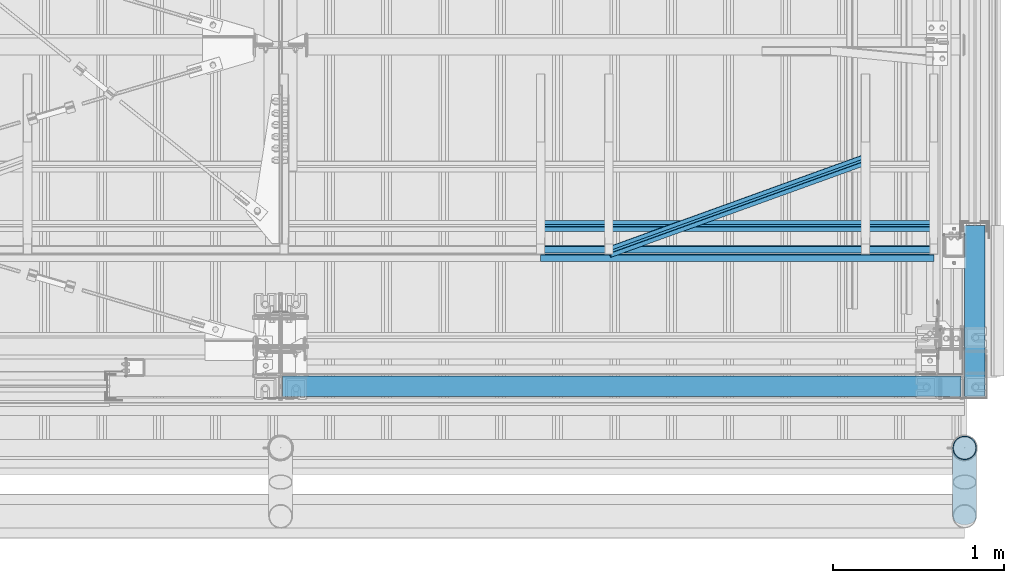
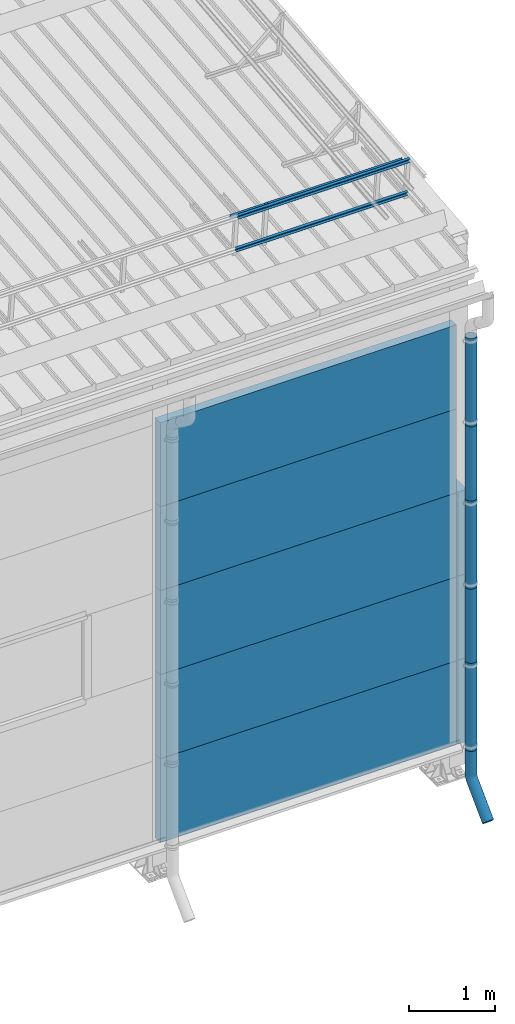
# One storey, part 69 of 709: 18 beams, 18 elements without a shape of their own.
"""IFC4 building model written with IfcOpenShell, lengths in millimetres."""

from ifc_helpers import new_model, entity, si_unit, direction, frame, origin_with_axes, place, context, subcontext, project, spatial, line, indexed_curve, outline, extrude, material, element, aggregate, save


model = new_model("IFC4")

# Units and contexts
model_context = context("Model", 3, precision=0.2, world=origin_with_axes(), true_north=direction((0.0, 1.0)))
body_context = subcontext(model_context, "Body", "Model", "MODEL_VIEW")
ifc_project = project(units=[si_unit("LENGTHUNIT", "METRE", prefix="MILLI"), si_unit("AREAUNIT", "SQUARE_METRE"), si_unit("VOLUMEUNIT", "CUBIC_METRE"), si_unit("MASSUNIT", "GRAM", prefix="KILO"), si_unit("TIMEUNIT", "SECOND"), si_unit("PLANEANGLEUNIT", "RADIAN"), si_unit("SOLIDANGLEUNIT", "STERADIAN"), si_unit("THERMODYNAMICTEMPERATUREUNIT", "DEGREE_CELSIUS"), si_unit("LUMINOUSINTENSITYUNIT", "LUMEN")], contexts=[model_context])

# Site, building, storey
site_placement = place(None, origin_with_axes())
site = spatial("IfcSite", under=ifc_project, at=site_placement, CompositionType="ELEMENT")
building_placement = place(site_placement, origin_with_axes())
building = spatial("IfcBuilding", under=site, at=building_placement, Name="Undefined", CompositionType="ELEMENT")
storey_placement = place(building_placement, origin_with_axes())
storey = spatial("IfcBuildingStorey", under=building, at=storey_placement, Name="Undefined", CompositionType="ELEMENT", Elevation=0.0)

# Assembly, beam
assembly_1_placement = place(storey_placement, frame((47520.0, 691.31008, 8152.29341), z_axis=(0.0, -0.9950371902, -0.099503719), x_axis=(1.0, 0.0, 0.0)))
assembly_1 = element("IfcElementAssembly", 1, at=assembly_1_placement, inside=storey)
ifc_material_1 = material(Name="Steel_Undefined", Category="STEEL")
beam_1_placement = place(assembly_1_placement, origin_with_axes())
beam_1 = element("IfcBeam", 2, at=beam_1_placement, material=ifc_material_1, ObjectType="607", context=body_context, shape_type="SolidModel", body=[
    extrude(outline(indexed_curve([(-20.0, -25.0), (20.0, -25.0), (20.0, -22.5), (-17.5, -22.5), (-17.5, 22.5), (20.0, 22.5), (20.0, 25.0), (-20.0, 25.0)], segments=[line(1, 2, 3, 4, 5, 6, 7, 8, 1)])), frame((0.0, 0.0, 0.0), z_axis=(-1.0, 0.0, 0.0), x_axis=(0.0, 0.0, 1.0)), (0.0, 0.0, -1.0), 2300.0),
])
aggregate(assembly_1, [beam_1])

assembly_2_placement = place(storey_placement, frame((47520.0, 741.06194, 7654.77481), z_axis=(0.0, -0.9950371902, -0.099503719), x_axis=(1.0, 0.0, 0.0)))
assembly_2 = element("IfcElementAssembly", 3, at=assembly_2_placement, inside=storey)
beam_2_placement = place(assembly_2_placement, origin_with_axes())
beam_2 = element("IfcBeam", 4, at=beam_2_placement, material=ifc_material_1, ObjectType="607", context=body_context, shape_type="SolidModel", body=[
    extrude(outline(indexed_curve([(-20.0, -25.0), (20.0, -25.0), (20.0, -22.5), (-17.5, -22.5), (-17.5, 22.5), (20.0, 22.5), (20.0, 25.0), (-20.0, 25.0)], segments=[line(1, 2, 3, 4, 5, 6, 7, 8, 1)])), frame((0.0, 0.0, 0.0), z_axis=(-1.0, 0.0, 0.0), x_axis=(0.0, 0.0, 1.0)), (0.0, 0.0, -1.0), 2300.0),
])
aggregate(assembly_2, [beam_2])

assembly_3_placement = place(storey_placement, frame((47520.0, 878.66704, 8043.11507), z_axis=(0.0, 0.6332377902, 0.7739572992), x_axis=(1.0, 0.0, 0.0)))
assembly_3 = element("IfcElementAssembly", 5, at=assembly_3_placement, inside=storey)
beam_3_placement = place(assembly_3_placement, origin_with_axes())
beam_3 = element("IfcBeam", 6, at=beam_3_placement, material=ifc_material_1, ObjectType="607", context=body_context, shape_type="SolidModel", body=[
    extrude(outline(indexed_curve([(-20.0, -25.0), (20.0, -25.0), (20.0, -22.5), (-17.5, -22.5), (-17.5, 22.5), (20.0, 22.5), (20.0, 25.0), (-20.0, 25.0)], segments=[line(1, 2, 3, 4, 5, 6, 7, 8, 1)])), frame((0.0, 0.0, 0.0), z_axis=(-1.0, 0.0, 0.0), x_axis=(0.0, 0.0, 1.0)), (0.0, 0.0, -1.0), 2300.0),
])
aggregate(assembly_3, [beam_3])

assembly_4_placement = place(storey_placement, frame((47920.0, 723.87558, 8169.76263), z_axis=(0.0, 0.6332377902, 0.7739572992), x_axis=(0.9061831398, 0.3272952929, -0.2677870579)))
assembly_4 = element("IfcElementAssembly", 7, at=assembly_4_placement, inside=storey)
beam_4_placement = place(assembly_4_placement, origin_with_axes())
beam_4 = element("IfcBeam", 8, at=beam_4_placement, material=ifc_material_1, ObjectType="605", context=body_context, shape_type="SolidModel", body=[
    extrude(outline(indexed_curve([(-20.0, -25.0), (20.0, -25.0), (20.0, -22.5), (-17.5, -22.5), (-17.5, 22.5), (20.0, 22.5), (20.0, 25.0), (-20.0, 25.0)], segments=[line(1, 2, 3, 4, 5, 6, 7, 8, 1)])), frame((0.0, 0.0, 0.0), z_axis=(-1.0, 0.0, 0.0), x_axis=(0.0, 0.0, 1.0)), (0.0, 0.0, -1.0), 1655.29454),
])
aggregate(assembly_4, [beam_4])

assembly_5_placement = place(storey_placement, frame((46010.0, -60.0, 895.0), z_axis=(0.0, 0.0, -1.0), x_axis=(1.0, 0.0, 0.0)))
assembly_5 = element("IfcElementAssembly", 9, at=assembly_5_placement, inside=storey)
ifc_material_2 = material(Name="Insulation", Category="Insulation")
beam_5_placement = place(assembly_5_placement, origin_with_axes())
beam_5 = element("IfcBeam", 10, at=beam_5_placement, material=ifc_material_2, ObjectType="P-102", context=body_context, shape_type="SolidModel", body=[
    extrude(outline(indexed_curve([(-595.0, -60.0), (595.0, -60.0), (595.0, 60.0), (-595.0, 60.0)], segments=[line(1, 2, 3, 4, 1)])), frame((0.0, 0.0, 0.0), z_axis=(-1.0, 0.0, 0.0), x_axis=(0.0, 0.0, 1.0)), (0.0, 0.0, -1.0), 3970.0),
])
aggregate(assembly_5, [beam_5])

assembly_6_placement = place(storey_placement, frame((46010.0, -60.0, 2085.0), z_axis=(0.0, 0.0, -1.0), x_axis=(1.0, 0.0, 0.0)))
assembly_6 = element("IfcElementAssembly", 11, at=assembly_6_placement, inside=storey)
beam_6_placement = place(assembly_6_placement, origin_with_axes())
beam_6 = element("IfcBeam", 12, at=beam_6_placement, material=ifc_material_2, ObjectType="P-102", context=body_context, shape_type="SolidModel", body=[
    extrude(outline(indexed_curve([(-595.0, -60.0), (595.0, -60.0), (595.0, 60.0), (-595.0, 60.0)], segments=[line(1, 2, 3, 4, 1)])), frame((0.0, 0.0, 0.0), z_axis=(-1.0, 0.0, 0.0), x_axis=(0.0, 0.0, 1.0)), (0.0, 0.0, -1.0), 3970.0),
])
aggregate(assembly_6, [beam_6])

assembly_7_placement = place(storey_placement, frame((46010.0, -60.0, 3275.0), z_axis=(0.0, 0.0, -1.0), x_axis=(1.0, 0.0, 0.0)))
assembly_7 = element("IfcElementAssembly", 13, at=assembly_7_placement, inside=storey)
beam_7_placement = place(assembly_7_placement, origin_with_axes())
beam_7 = element("IfcBeam", 14, at=beam_7_placement, material=ifc_material_2, ObjectType="P-102", context=body_context, shape_type="SolidModel", body=[
    extrude(outline(indexed_curve([(-595.0, -60.0), (595.0, -60.0), (595.0, 60.0), (-595.0, 60.0)], segments=[line(1, 2, 3, 4, 1)])), frame((0.0, 0.0, 0.0), z_axis=(-1.0, 0.0, 0.0), x_axis=(0.0, 0.0, 1.0)), (0.0, 0.0, -1.0), 3970.0),
])
aggregate(assembly_7, [beam_7])

assembly_8_placement = place(storey_placement, frame((46010.0, -60.0, 4465.0), z_axis=(0.0, 0.0, -1.0), x_axis=(1.0, 0.0, 0.0)))
assembly_8 = element("IfcElementAssembly", 15, at=assembly_8_placement, inside=storey)
beam_8_placement = place(assembly_8_placement, origin_with_axes())
beam_8 = element("IfcBeam", 16, at=beam_8_placement, material=ifc_material_2, ObjectType="P-102", context=body_context, shape_type="SolidModel", body=[
    extrude(outline(indexed_curve([(-595.0, -60.0), (595.0, -60.0), (595.0, 60.0), (-595.0, 60.0)], segments=[line(1, 2, 3, 4, 1)])), frame((0.0, 0.0, 0.0), z_axis=(-1.0, 0.0, 0.0), x_axis=(0.0, 0.0, 1.0)), (0.0, 0.0, -1.0), 3970.0),
])
aggregate(assembly_8, [beam_8])

assembly_9_placement = place(storey_placement, frame((46010.0, -60.0, 5655.0), z_axis=(0.0, 0.0, -1.0), x_axis=(1.0, 0.0, 0.0)))
assembly_9 = element("IfcElementAssembly", 17, at=assembly_9_placement, inside=storey)
beam_9_placement = place(assembly_9_placement, origin_with_axes())
beam_9 = element("IfcBeam", 18, at=beam_9_placement, material=ifc_material_2, ObjectType="P-102", context=body_context, shape_type="SolidModel", body=[
    extrude(outline(indexed_curve([(-595.0, -60.0), (595.0, -60.0), (595.0, 60.0), (-595.0, 60.0)], segments=[line(1, 2, 3, 4, 1)])), frame((0.0, 0.0, 0.0), z_axis=(-1.0, 0.0, 0.0), x_axis=(0.0, 0.0, 1.0)), (0.0, 0.0, -1.0), 3970.0),
])
aggregate(assembly_9, [beam_9])

assembly_10_placement = place(storey_placement, frame((50000.0, -420.0, 6276.92297), z_axis=(0.0, 1.0, 0.0), x_axis=(0.0, 0.0, -1.0)))
assembly_10 = element("IfcElementAssembly", 19, at=assembly_10_placement, inside=storey)
beam_10_placement = place(assembly_10_placement, origin_with_axes())
beam_10 = element("IfcBeam", 20, at=beam_10_placement, material=ifc_material_1, ObjectType="614", context=body_context, shape_type="SolidModel", body=[
    extrude(outline(indexed_curve([(70.0, 0.0), (69.61653, 7.31699), (68.47033, 14.55382), (66.57396, 21.63119), (63.94818, 28.47157), (60.62178, 35.0), (56.63119, 41.14497), (52.02014, 46.83914), (46.83914, 52.02014), (41.14497, 56.63119), (35.0, 60.62178), (28.47157, 63.94818), (21.63119, 66.57396), (14.55382, 68.47033), (7.31699, 69.61653), (0.0, 70.0), (-7.31699, 69.61653), (-14.55382, 68.47033), (-21.63119, 66.57396), (-28.47157, 63.94818), (-35.0, 60.62178), (-41.14497, 56.63119), (-46.83914, 52.02014), (-52.02014, 46.83914), (-56.63119, 41.14497), (-60.62178, 35.0), (-63.94818, 28.47157), (-66.57396, 21.63119), (-68.47033, 14.55382), (-69.61653, 7.31699), (-70.0, 0.0), (-69.61653, -7.31699), (-68.47033, -14.55382), (-66.57396, -21.63119), (-63.94818, -28.47157), (-60.62178, -35.0), (-56.63119, -41.14497), (-52.02014, -46.83914), (-46.83914, -52.02014), (-41.14497, -56.63119), (-35.0, -60.62178), (-28.47157, -63.94818), (-21.63119, -66.57396), (-14.55382, -68.47033), (-7.31699, -69.61653), (0.0, -70.0), (7.31699, -69.61653), (14.55382, -68.47033), (21.63119, -66.57396), (28.47157, -63.94818), (35.0, -60.62178), (41.14497, -56.63119), (46.83914, -52.02014), (52.02014, -46.83914), (56.63119, -41.14497), (60.62178, -35.0), (63.94818, -28.47157), (66.57396, -21.63119), (68.47033, -14.55382), (69.61653, -7.31699)], segments=[line(1, 2, 3, 4, 5, 6, 7, 8, 9, 10, 11, 12, 13, 14, 15, 16, 17, 18, 19, 20, 21, 22, 23, 24, 25, 26, 27, 28, 29, 30, 31, 32, 33, 34, 35, 36, 37, 38, 39, 40, 41, 42, 43, 44, 45, 46, 47, 48, 49, 50, 51, 52, 53, 54, 55, 56, 57, 58, 59, 60, 1)]), holes=[indexed_curve([(65.0, 0.0), (64.64392, -6.79435), (63.57959, -13.51426), (61.81867, -20.0861), (59.38045, -26.43788), (56.29165, -32.5), (52.5861, -38.20604), (48.30441, -43.49349), (43.49349, -48.30441), (38.20604, -52.5861), (32.5, -56.29165), (26.43788, -59.38045), (20.0861, -61.81867), (13.51426, -63.57959), (6.79435, -64.64392), (0.0, -65.0), (-6.79435, -64.64392), (-13.51426, -63.57959), (-20.0861, -61.81867), (-26.43788, -59.38045), (-32.5, -56.29165), (-38.20604, -52.5861), (-43.49349, -48.30441), (-48.30441, -43.49349), (-52.5861, -38.20604), (-56.29165, -32.5), (-59.38045, -26.43788), (-61.81867, -20.0861), (-63.57959, -13.51426), (-64.64392, -6.79435), (-65.0, 0.0), (-64.64392, 6.79435), (-63.57959, 13.51426), (-61.81867, 20.0861), (-59.38045, 26.43788), (-56.29165, 32.5), (-52.5861, 38.20604), (-48.30441, 43.49349), (-43.49349, 48.30441), (-38.20604, 52.5861), (-32.5, 56.29165), (-26.43788, 59.38045), (-20.0861, 61.81867), (-13.51426, 63.57959), (-6.79435, 64.64392), (0.0, 65.0), (6.79435, 64.64392), (13.51426, 63.57959), (20.0861, 61.81867), (26.43788, 59.38045), (32.5, 56.29165), (38.20604, 52.5861), (43.49349, 48.30441), (48.30441, 43.49349), (52.5861, 38.20604), (56.29165, 32.5), (59.38045, 26.43788), (61.81867, 20.0861), (63.57959, 13.51426), (64.64392, 6.79435)], segments=[line(1, 2, 3, 4, 5, 6, 7, 8, 9, 10, 11, 12, 13, 14, 15, 16, 17, 18, 19, 20, 21, 22, 23, 24, 25, 26, 27, 28, 29, 30, 31, 32, 33, 34, 35, 36, 37, 38, 39, 40, 41, 42, 43, 44, 45, 46, 47, 48, 49, 50, 51, 52, 53, 54, 55, 56, 57, 58, 59, 60, 1)])]), frame((0.0, 0.0, 0.0), z_axis=(-1.0, 0.0, 0.0), x_axis=(0.0, 0.0, 1.0)), (0.0, 0.0, -1.0), 1250.0),
])
aggregate(assembly_10, [beam_10])

assembly_11_placement = place(storey_placement, frame((50000.0, -420.0, 5126.92297), z_axis=(0.0, 1.0, 0.0), x_axis=(0.0, 0.0, -1.0)))
assembly_11 = element("IfcElementAssembly", 21, at=assembly_11_placement, inside=storey)
beam_11_placement = place(assembly_11_placement, origin_with_axes())
beam_11 = element("IfcBeam", 22, at=beam_11_placement, material=ifc_material_1, ObjectType="614", context=body_context, shape_type="SolidModel", body=[
    extrude(outline(indexed_curve([(70.0, 0.0), (69.61653, 7.31699), (68.47033, 14.55382), (66.57396, 21.63119), (63.94818, 28.47157), (60.62178, 35.0), (56.63119, 41.14497), (52.02014, 46.83914), (46.83914, 52.02014), (41.14497, 56.63119), (35.0, 60.62178), (28.47157, 63.94818), (21.63119, 66.57396), (14.55382, 68.47033), (7.31699, 69.61653), (0.0, 70.0), (-7.31699, 69.61653), (-14.55382, 68.47033), (-21.63119, 66.57396), (-28.47157, 63.94818), (-35.0, 60.62178), (-41.14497, 56.63119), (-46.83914, 52.02014), (-52.02014, 46.83914), (-56.63119, 41.14497), (-60.62178, 35.0), (-63.94818, 28.47157), (-66.57396, 21.63119), (-68.47033, 14.55382), (-69.61653, 7.31699), (-70.0, 0.0), (-69.61653, -7.31699), (-68.47033, -14.55382), (-66.57396, -21.63119), (-63.94818, -28.47157), (-60.62178, -35.0), (-56.63119, -41.14497), (-52.02014, -46.83914), (-46.83914, -52.02014), (-41.14497, -56.63119), (-35.0, -60.62178), (-28.47157, -63.94818), (-21.63119, -66.57396), (-14.55382, -68.47033), (-7.31699, -69.61653), (0.0, -70.0), (7.31699, -69.61653), (14.55382, -68.47033), (21.63119, -66.57396), (28.47157, -63.94818), (35.0, -60.62178), (41.14497, -56.63119), (46.83914, -52.02014), (52.02014, -46.83914), (56.63119, -41.14497), (60.62178, -35.0), (63.94818, -28.47157), (66.57396, -21.63119), (68.47033, -14.55382), (69.61653, -7.31699)], segments=[line(1, 2, 3, 4, 5, 6, 7, 8, 9, 10, 11, 12, 13, 14, 15, 16, 17, 18, 19, 20, 21, 22, 23, 24, 25, 26, 27, 28, 29, 30, 31, 32, 33, 34, 35, 36, 37, 38, 39, 40, 41, 42, 43, 44, 45, 46, 47, 48, 49, 50, 51, 52, 53, 54, 55, 56, 57, 58, 59, 60, 1)]), holes=[indexed_curve([(65.0, 0.0), (64.64392, -6.79435), (63.57959, -13.51426), (61.81867, -20.0861), (59.38045, -26.43788), (56.29165, -32.5), (52.5861, -38.20604), (48.30441, -43.49349), (43.49349, -48.30441), (38.20604, -52.5861), (32.5, -56.29165), (26.43788, -59.38045), (20.0861, -61.81867), (13.51426, -63.57959), (6.79435, -64.64392), (0.0, -65.0), (-6.79435, -64.64392), (-13.51426, -63.57959), (-20.0861, -61.81867), (-26.43788, -59.38045), (-32.5, -56.29165), (-38.20604, -52.5861), (-43.49349, -48.30441), (-48.30441, -43.49349), (-52.5861, -38.20604), (-56.29165, -32.5), (-59.38045, -26.43788), (-61.81867, -20.0861), (-63.57959, -13.51426), (-64.64392, -6.79435), (-65.0, 0.0), (-64.64392, 6.79435), (-63.57959, 13.51426), (-61.81867, 20.0861), (-59.38045, 26.43788), (-56.29165, 32.5), (-52.5861, 38.20604), (-48.30441, 43.49349), (-43.49349, 48.30441), (-38.20604, 52.5861), (-32.5, 56.29165), (-26.43788, 59.38045), (-20.0861, 61.81867), (-13.51426, 63.57959), (-6.79435, 64.64392), (0.0, 65.0), (6.79435, 64.64392), (13.51426, 63.57959), (20.0861, 61.81867), (26.43788, 59.38045), (32.5, 56.29165), (38.20604, 52.5861), (43.49349, 48.30441), (48.30441, 43.49349), (52.5861, 38.20604), (56.29165, 32.5), (59.38045, 26.43788), (61.81867, 20.0861), (63.57959, 13.51426), (64.64392, 6.79435)], segments=[line(1, 2, 3, 4, 5, 6, 7, 8, 9, 10, 11, 12, 13, 14, 15, 16, 17, 18, 19, 20, 21, 22, 23, 24, 25, 26, 27, 28, 29, 30, 31, 32, 33, 34, 35, 36, 37, 38, 39, 40, 41, 42, 43, 44, 45, 46, 47, 48, 49, 50, 51, 52, 53, 54, 55, 56, 57, 58, 59, 60, 1)])]), frame((0.0, 0.0, 0.0), z_axis=(-1.0, 0.0, 0.0), x_axis=(0.0, 0.0, 1.0)), (0.0, 0.0, -1.0), 1250.0),
])
aggregate(assembly_11, [beam_11])

assembly_12_placement = place(storey_placement, frame((50000.0, -420.0, 3976.92297), z_axis=(0.0, 1.0, 0.0), x_axis=(0.0, 0.0, -1.0)))
assembly_12 = element("IfcElementAssembly", 23, at=assembly_12_placement, inside=storey)
beam_12_placement = place(assembly_12_placement, origin_with_axes())
beam_12 = element("IfcBeam", 24, at=beam_12_placement, material=ifc_material_1, ObjectType="614", context=body_context, shape_type="SolidModel", body=[
    extrude(outline(indexed_curve([(70.0, 0.0), (69.61653, 7.31699), (68.47033, 14.55382), (66.57396, 21.63119), (63.94818, 28.47157), (60.62178, 35.0), (56.63119, 41.14497), (52.02014, 46.83914), (46.83914, 52.02014), (41.14497, 56.63119), (35.0, 60.62178), (28.47157, 63.94818), (21.63119, 66.57396), (14.55382, 68.47033), (7.31699, 69.61653), (0.0, 70.0), (-7.31699, 69.61653), (-14.55382, 68.47033), (-21.63119, 66.57396), (-28.47157, 63.94818), (-35.0, 60.62178), (-41.14497, 56.63119), (-46.83914, 52.02014), (-52.02014, 46.83914), (-56.63119, 41.14497), (-60.62178, 35.0), (-63.94818, 28.47157), (-66.57396, 21.63119), (-68.47033, 14.55382), (-69.61653, 7.31699), (-70.0, 0.0), (-69.61653, -7.31699), (-68.47033, -14.55382), (-66.57396, -21.63119), (-63.94818, -28.47157), (-60.62178, -35.0), (-56.63119, -41.14497), (-52.02014, -46.83914), (-46.83914, -52.02014), (-41.14497, -56.63119), (-35.0, -60.62178), (-28.47157, -63.94818), (-21.63119, -66.57396), (-14.55382, -68.47033), (-7.31699, -69.61653), (0.0, -70.0), (7.31699, -69.61653), (14.55382, -68.47033), (21.63119, -66.57396), (28.47157, -63.94818), (35.0, -60.62178), (41.14497, -56.63119), (46.83914, -52.02014), (52.02014, -46.83914), (56.63119, -41.14497), (60.62178, -35.0), (63.94818, -28.47157), (66.57396, -21.63119), (68.47033, -14.55382), (69.61653, -7.31699)], segments=[line(1, 2, 3, 4, 5, 6, 7, 8, 9, 10, 11, 12, 13, 14, 15, 16, 17, 18, 19, 20, 21, 22, 23, 24, 25, 26, 27, 28, 29, 30, 31, 32, 33, 34, 35, 36, 37, 38, 39, 40, 41, 42, 43, 44, 45, 46, 47, 48, 49, 50, 51, 52, 53, 54, 55, 56, 57, 58, 59, 60, 1)]), holes=[indexed_curve([(65.0, 0.0), (64.64392, -6.79435), (63.57959, -13.51426), (61.81867, -20.0861), (59.38045, -26.43788), (56.29165, -32.5), (52.5861, -38.20604), (48.30441, -43.49349), (43.49349, -48.30441), (38.20604, -52.5861), (32.5, -56.29165), (26.43788, -59.38045), (20.0861, -61.81867), (13.51426, -63.57959), (6.79435, -64.64392), (0.0, -65.0), (-6.79435, -64.64392), (-13.51426, -63.57959), (-20.0861, -61.81867), (-26.43788, -59.38045), (-32.5, -56.29165), (-38.20604, -52.5861), (-43.49349, -48.30441), (-48.30441, -43.49349), (-52.5861, -38.20604), (-56.29165, -32.5), (-59.38045, -26.43788), (-61.81867, -20.0861), (-63.57959, -13.51426), (-64.64392, -6.79435), (-65.0, 0.0), (-64.64392, 6.79435), (-63.57959, 13.51426), (-61.81867, 20.0861), (-59.38045, 26.43788), (-56.29165, 32.5), (-52.5861, 38.20604), (-48.30441, 43.49349), (-43.49349, 48.30441), (-38.20604, 52.5861), (-32.5, 56.29165), (-26.43788, 59.38045), (-20.0861, 61.81867), (-13.51426, 63.57959), (-6.79435, 64.64392), (0.0, 65.0), (6.79435, 64.64392), (13.51426, 63.57959), (20.0861, 61.81867), (26.43788, 59.38045), (32.5, 56.29165), (38.20604, 52.5861), (43.49349, 48.30441), (48.30441, 43.49349), (52.5861, 38.20604), (56.29165, 32.5), (59.38045, 26.43788), (61.81867, 20.0861), (63.57959, 13.51426), (64.64392, 6.79435)], segments=[line(1, 2, 3, 4, 5, 6, 7, 8, 9, 10, 11, 12, 13, 14, 15, 16, 17, 18, 19, 20, 21, 22, 23, 24, 25, 26, 27, 28, 29, 30, 31, 32, 33, 34, 35, 36, 37, 38, 39, 40, 41, 42, 43, 44, 45, 46, 47, 48, 49, 50, 51, 52, 53, 54, 55, 56, 57, 58, 59, 60, 1)])]), frame((0.0, 0.0, 0.0), z_axis=(-1.0, 0.0, 0.0), x_axis=(0.0, 0.0, 1.0)), (0.0, 0.0, -1.0), 1250.0),
])
aggregate(assembly_12, [beam_12])

assembly_13_placement = place(storey_placement, frame((50000.0, -420.0, 2826.92297), z_axis=(0.0, 1.0, 0.0), x_axis=(0.0, 0.0, -1.0)))
assembly_13 = element("IfcElementAssembly", 25, at=assembly_13_placement, inside=storey)
beam_13_placement = place(assembly_13_placement, origin_with_axes())
beam_13 = element("IfcBeam", 26, at=beam_13_placement, material=ifc_material_1, ObjectType="614", context=body_context, shape_type="SolidModel", body=[
    extrude(outline(indexed_curve([(70.0, 0.0), (69.61653, 7.31699), (68.47033, 14.55382), (66.57396, 21.63119), (63.94818, 28.47157), (60.62178, 35.0), (56.63119, 41.14497), (52.02014, 46.83914), (46.83914, 52.02014), (41.14497, 56.63119), (35.0, 60.62178), (28.47157, 63.94818), (21.63119, 66.57396), (14.55382, 68.47033), (7.31699, 69.61653), (0.0, 70.0), (-7.31699, 69.61653), (-14.55382, 68.47033), (-21.63119, 66.57396), (-28.47157, 63.94818), (-35.0, 60.62178), (-41.14497, 56.63119), (-46.83914, 52.02014), (-52.02014, 46.83914), (-56.63119, 41.14497), (-60.62178, 35.0), (-63.94818, 28.47157), (-66.57396, 21.63119), (-68.47033, 14.55382), (-69.61653, 7.31699), (-70.0, 0.0), (-69.61653, -7.31699), (-68.47033, -14.55382), (-66.57396, -21.63119), (-63.94818, -28.47157), (-60.62178, -35.0), (-56.63119, -41.14497), (-52.02014, -46.83914), (-46.83914, -52.02014), (-41.14497, -56.63119), (-35.0, -60.62178), (-28.47157, -63.94818), (-21.63119, -66.57396), (-14.55382, -68.47033), (-7.31699, -69.61653), (0.0, -70.0), (7.31699, -69.61653), (14.55382, -68.47033), (21.63119, -66.57396), (28.47157, -63.94818), (35.0, -60.62178), (41.14497, -56.63119), (46.83914, -52.02014), (52.02014, -46.83914), (56.63119, -41.14497), (60.62178, -35.0), (63.94818, -28.47157), (66.57396, -21.63119), (68.47033, -14.55382), (69.61653, -7.31699)], segments=[line(1, 2, 3, 4, 5, 6, 7, 8, 9, 10, 11, 12, 13, 14, 15, 16, 17, 18, 19, 20, 21, 22, 23, 24, 25, 26, 27, 28, 29, 30, 31, 32, 33, 34, 35, 36, 37, 38, 39, 40, 41, 42, 43, 44, 45, 46, 47, 48, 49, 50, 51, 52, 53, 54, 55, 56, 57, 58, 59, 60, 1)]), holes=[indexed_curve([(65.0, 0.0), (64.64392, -6.79435), (63.57959, -13.51426), (61.81867, -20.0861), (59.38045, -26.43788), (56.29165, -32.5), (52.5861, -38.20604), (48.30441, -43.49349), (43.49349, -48.30441), (38.20604, -52.5861), (32.5, -56.29165), (26.43788, -59.38045), (20.0861, -61.81867), (13.51426, -63.57959), (6.79435, -64.64392), (0.0, -65.0), (-6.79435, -64.64392), (-13.51426, -63.57959), (-20.0861, -61.81867), (-26.43788, -59.38045), (-32.5, -56.29165), (-38.20604, -52.5861), (-43.49349, -48.30441), (-48.30441, -43.49349), (-52.5861, -38.20604), (-56.29165, -32.5), (-59.38045, -26.43788), (-61.81867, -20.0861), (-63.57959, -13.51426), (-64.64392, -6.79435), (-65.0, 0.0), (-64.64392, 6.79435), (-63.57959, 13.51426), (-61.81867, 20.0861), (-59.38045, 26.43788), (-56.29165, 32.5), (-52.5861, 38.20604), (-48.30441, 43.49349), (-43.49349, 48.30441), (-38.20604, 52.5861), (-32.5, 56.29165), (-26.43788, 59.38045), (-20.0861, 61.81867), (-13.51426, 63.57959), (-6.79435, 64.64392), (0.0, 65.0), (6.79435, 64.64392), (13.51426, 63.57959), (20.0861, 61.81867), (26.43788, 59.38045), (32.5, 56.29165), (38.20604, 52.5861), (43.49349, 48.30441), (48.30441, 43.49349), (52.5861, 38.20604), (56.29165, 32.5), (59.38045, 26.43788), (61.81867, 20.0861), (63.57959, 13.51426), (64.64392, 6.79435)], segments=[line(1, 2, 3, 4, 5, 6, 7, 8, 9, 10, 11, 12, 13, 14, 15, 16, 17, 18, 19, 20, 21, 22, 23, 24, 25, 26, 27, 28, 29, 30, 31, 32, 33, 34, 35, 36, 37, 38, 39, 40, 41, 42, 43, 44, 45, 46, 47, 48, 49, 50, 51, 52, 53, 54, 55, 56, 57, 58, 59, 60, 1)])]), frame((0.0, 0.0, 0.0), z_axis=(-1.0, 0.0, 0.0), x_axis=(0.0, 0.0, 1.0)), (0.0, 0.0, -1.0), 1250.0),
])
aggregate(assembly_13, [beam_13])

assembly_14_placement = place(storey_placement, frame((50000.0, -420.0, 1676.92297), z_axis=(0.0, 1.0, 0.0), x_axis=(0.0, 0.0, -1.0)))
assembly_14 = element("IfcElementAssembly", 27, at=assembly_14_placement, inside=storey)
beam_14_placement = place(assembly_14_placement, origin_with_axes())
beam_14 = element("IfcBeam", 28, at=beam_14_placement, material=ifc_material_1, ObjectType="614", context=body_context, shape_type="SolidModel", body=[
    extrude(outline(indexed_curve([(70.0, 0.0), (69.61653, 7.31699), (68.47033, 14.55382), (66.57396, 21.63119), (63.94818, 28.47157), (60.62178, 35.0), (56.63119, 41.14497), (52.02014, 46.83914), (46.83914, 52.02014), (41.14497, 56.63119), (35.0, 60.62178), (28.47157, 63.94818), (21.63119, 66.57396), (14.55382, 68.47033), (7.31699, 69.61653), (0.0, 70.0), (-7.31699, 69.61653), (-14.55382, 68.47033), (-21.63119, 66.57396), (-28.47157, 63.94818), (-35.0, 60.62178), (-41.14497, 56.63119), (-46.83914, 52.02014), (-52.02014, 46.83914), (-56.63119, 41.14497), (-60.62178, 35.0), (-63.94818, 28.47157), (-66.57396, 21.63119), (-68.47033, 14.55382), (-69.61653, 7.31699), (-70.0, 0.0), (-69.61653, -7.31699), (-68.47033, -14.55382), (-66.57396, -21.63119), (-63.94818, -28.47157), (-60.62178, -35.0), (-56.63119, -41.14497), (-52.02014, -46.83914), (-46.83914, -52.02014), (-41.14497, -56.63119), (-35.0, -60.62178), (-28.47157, -63.94818), (-21.63119, -66.57396), (-14.55382, -68.47033), (-7.31699, -69.61653), (0.0, -70.0), (7.31699, -69.61653), (14.55382, -68.47033), (21.63119, -66.57396), (28.47157, -63.94818), (35.0, -60.62178), (41.14497, -56.63119), (46.83914, -52.02014), (52.02014, -46.83914), (56.63119, -41.14497), (60.62178, -35.0), (63.94818, -28.47157), (66.57396, -21.63119), (68.47033, -14.55382), (69.61653, -7.31699)], segments=[line(1, 2, 3, 4, 5, 6, 7, 8, 9, 10, 11, 12, 13, 14, 15, 16, 17, 18, 19, 20, 21, 22, 23, 24, 25, 26, 27, 28, 29, 30, 31, 32, 33, 34, 35, 36, 37, 38, 39, 40, 41, 42, 43, 44, 45, 46, 47, 48, 49, 50, 51, 52, 53, 54, 55, 56, 57, 58, 59, 60, 1)]), holes=[indexed_curve([(65.0, 0.0), (64.64392, -6.79435), (63.57959, -13.51426), (61.81867, -20.0861), (59.38045, -26.43788), (56.29165, -32.5), (52.5861, -38.20604), (48.30441, -43.49349), (43.49349, -48.30441), (38.20604, -52.5861), (32.5, -56.29165), (26.43788, -59.38045), (20.0861, -61.81867), (13.51426, -63.57959), (6.79435, -64.64392), (0.0, -65.0), (-6.79435, -64.64392), (-13.51426, -63.57959), (-20.0861, -61.81867), (-26.43788, -59.38045), (-32.5, -56.29165), (-38.20604, -52.5861), (-43.49349, -48.30441), (-48.30441, -43.49349), (-52.5861, -38.20604), (-56.29165, -32.5), (-59.38045, -26.43788), (-61.81867, -20.0861), (-63.57959, -13.51426), (-64.64392, -6.79435), (-65.0, 0.0), (-64.64392, 6.79435), (-63.57959, 13.51426), (-61.81867, 20.0861), (-59.38045, 26.43788), (-56.29165, 32.5), (-52.5861, 38.20604), (-48.30441, 43.49349), (-43.49349, 48.30441), (-38.20604, 52.5861), (-32.5, 56.29165), (-26.43788, 59.38045), (-20.0861, 61.81867), (-13.51426, 63.57959), (-6.79435, 64.64392), (0.0, 65.0), (6.79435, 64.64392), (13.51426, 63.57959), (20.0861, 61.81867), (26.43788, 59.38045), (32.5, 56.29165), (38.20604, 52.5861), (43.49349, 48.30441), (48.30441, 43.49349), (52.5861, 38.20604), (56.29165, 32.5), (59.38045, 26.43788), (61.81867, 20.0861), (63.57959, 13.51426), (64.64392, 6.79435)], segments=[line(1, 2, 3, 4, 5, 6, 7, 8, 9, 10, 11, 12, 13, 14, 15, 16, 17, 18, 19, 20, 21, 22, 23, 24, 25, 26, 27, 28, 29, 30, 31, 32, 33, 34, 35, 36, 37, 38, 39, 40, 41, 42, 43, 44, 45, 46, 47, 48, 49, 50, 51, 52, 53, 54, 55, 56, 57, 58, 59, 60, 1)])]), frame((0.0, 0.0, 0.0), z_axis=(-1.0, 0.0, 0.0), x_axis=(0.0, 0.0, 1.0)), (0.0, 0.0, -1.0), 1250.0),
])
aggregate(assembly_14, [beam_14])

assembly_15_placement = place(storey_placement, frame((50000.0, -420.0, 526.92297), z_axis=(-1.0, 0.0, 0.0), x_axis=(0.0, 0.0, -1.0)))
assembly_15 = element("IfcElementAssembly", 29, at=assembly_15_placement, inside=storey)
beam_15_placement = place(assembly_15_placement, origin_with_axes())
beam_15 = element("IfcBeam", 30, at=beam_15_placement, material=ifc_material_1, ObjectType="617", context=body_context, shape_type="SolidModel", body=[
    entity("IfcSweptDiskSolid", entity("IfcIndexedPolyCurve", entity("IfcCartesianPointList3D", [[0.0, 0.0, 0.0], [448.2233, 0.0, 0.0], [496.05873, 9.51506, 0.0], [536.61165, 36.61165, 0.0], [900.0, 400.0, 0.0]]), [entity("IfcLineIndex", [1, 2]), entity("IfcArcIndex", [2, 3, 4]), entity("IfcLineIndex", [4, 5])]), 70.0, 65.0),
])
aggregate(assembly_15, [beam_15])

assembly_16_placement = place(storey_placement, frame((50060.0, -120.0, 895.0), z_axis=(0.0, 0.0, -1.0), x_axis=(0.0, 1.0, 0.0)))
assembly_16 = element("IfcElementAssembly", 31, at=assembly_16_placement, inside=storey)
beam_16_placement = place(assembly_16_placement, origin_with_axes())
beam_16 = element("IfcBeam", 32, at=beam_16_placement, material=ifc_material_2, ObjectType="P-143", context=body_context, shape_type="SolidModel", body=[
    extrude(outline(indexed_curve([(-595.0, -60.0), (595.0, -60.0), (595.0, 60.0), (-595.0, 60.0)], segments=[line(1, 2, 3, 4, 1)])), frame((0.0, 0.0, 0.0), z_axis=(-1.0, 0.0, 0.0), x_axis=(0.0, 0.0, 1.0)), (0.0, 0.0, -1.0), 1000.0),
])
aggregate(assembly_16, [beam_16])

assembly_17_placement = place(storey_placement, frame((50060.0, -120.0, 2085.0), z_axis=(0.0, 0.0, -1.0), x_axis=(0.0, 1.0, 0.0)))
assembly_17 = element("IfcElementAssembly", 33, at=assembly_17_placement, inside=storey)
beam_17_placement = place(assembly_17_placement, origin_with_axes())
beam_17 = element("IfcBeam", 34, at=beam_17_placement, material=ifc_material_2, ObjectType="P-143", context=body_context, shape_type="SolidModel", body=[
    extrude(outline(indexed_curve([(-595.0, -60.0), (595.0, -60.0), (595.0, 60.0), (-595.0, 60.0)], segments=[line(1, 2, 3, 4, 1)])), frame((0.0, 0.0, 0.0), z_axis=(-1.0, 0.0, 0.0), x_axis=(0.0, 0.0, 1.0)), (0.0, 0.0, -1.0), 1000.0),
])
aggregate(assembly_17, [beam_17])

assembly_18_placement = place(storey_placement, frame((50060.0, -120.0, 3275.0), z_axis=(0.0, 0.0, -1.0), x_axis=(0.0, 1.0, 0.0)))
assembly_18 = element("IfcElementAssembly", 35, at=assembly_18_placement, inside=storey)
beam_18_placement = place(assembly_18_placement, origin_with_axes())
beam_18 = element("IfcBeam", 36, at=beam_18_placement, material=ifc_material_2, ObjectType="P-143", context=body_context, shape_type="SolidModel", body=[
    extrude(outline(indexed_curve([(-595.0, -60.0), (595.0, -60.0), (595.0, 60.0), (-595.0, 60.0)], segments=[line(1, 2, 3, 4, 1)])), frame((0.0, 0.0, 0.0), z_axis=(-1.0, 0.0, 0.0), x_axis=(0.0, 0.0, 1.0)), (0.0, 0.0, -1.0), 1000.0),
])
aggregate(assembly_18, [beam_18])

save(model, "model.ifc")
